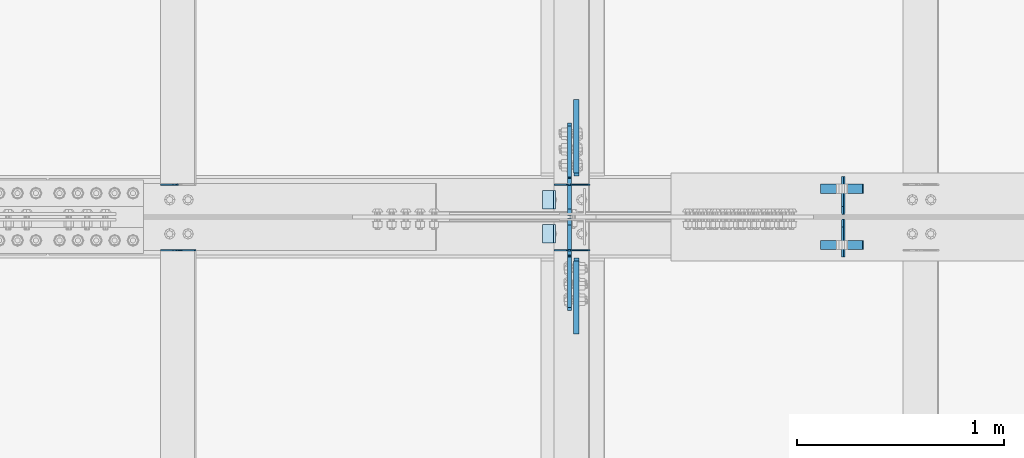
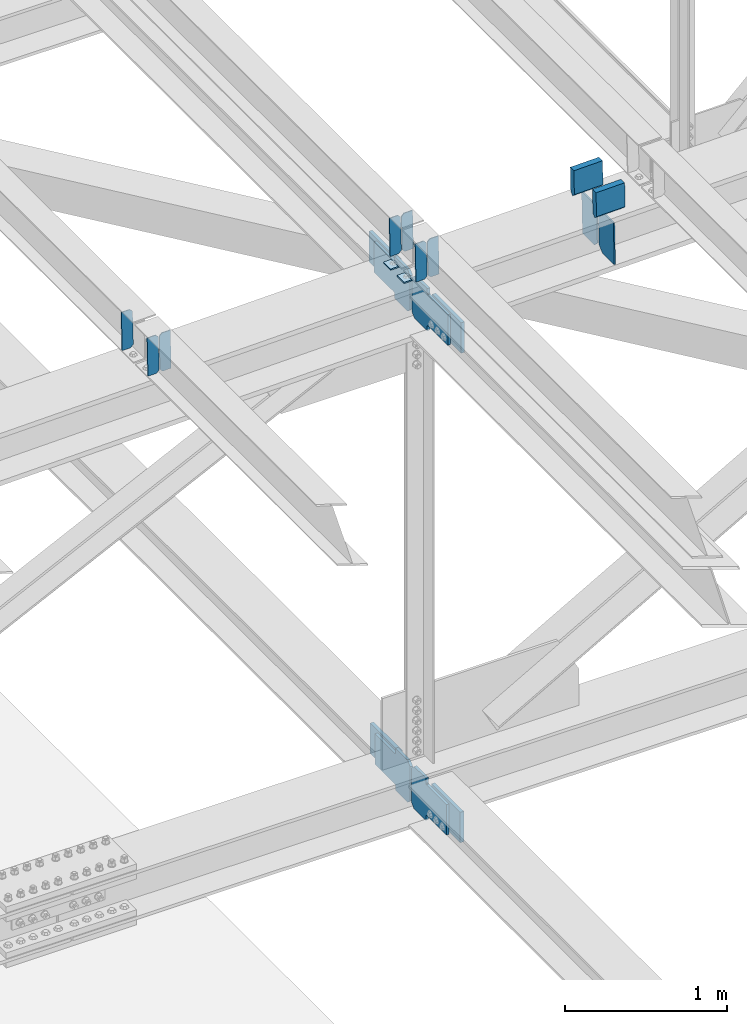
# One storey, part 3318 of 3843: 21 plates, 10 elements without a shape of their own.
"""IFC2X3 building model written with IfcOpenShell, lengths in millimetres."""

from ifc_helpers import new_model, si_unit, frame, origin_with_axes, place, context, subcontext, project, spatial, faceted_brep, material, type_object, element, aggregate, save


model = new_model("IFC2X3")

# Units and contexts
model_context = context("Model", 3, precision=1e-05, world=origin_with_axes())
body_context = subcontext(model_context, "Body", "Model", "MODEL_VIEW")
ifc_project = project(units=[si_unit("LENGTHUNIT", "METRE", prefix="MILLI"), si_unit("AREAUNIT", "SQUARE_METRE"), si_unit("VOLUMEUNIT", "CUBIC_METRE"), si_unit("MASSUNIT", "GRAM", prefix="KILO"), si_unit("TIMEUNIT", "SECOND"), si_unit("PLANEANGLEUNIT", "RADIAN"), si_unit("SOLIDANGLEUNIT", "STERADIAN"), si_unit("THERMODYNAMICTEMPERATUREUNIT", "DEGREE_CELSIUS"), si_unit("LUMINOUSINTENSITYUNIT", "LUMEN")], contexts=[model_context])

# Site, building, storey
site_placement = place(None, origin_with_axes())
site = spatial("IfcSite", under=ifc_project, at=site_placement, CompositionType="ELEMENT")
building_placement = place(site_placement, origin_with_axes())
building = spatial("IfcBuilding", under=site, at=building_placement, Name="Undefined", CompositionType="ELEMENT")
storey_placement = place(building_placement, origin_with_axes())
storey = spatial("IfcBuildingStorey", under=building, at=storey_placement, Name="Undefined", CompositionType="ELEMENT", Elevation=0.0)

# Assembly, plates
assembly_1_placement = place(storey_placement, origin_with_axes())
assembly_1 = element("IfcElementAssembly", 1, at=assembly_1_placement, inside=storey, Name="BEAM", AssemblyPlace="NOTDEFINED", PredefinedType="RIGID_FRAME")
ifc_material = material(Name="STEEL/A572-50")
plate_type_1 = type_object("IfcPlateType", PredefinedType="NOTDEFINED")
plate_1_placement = place(assembly_1_placement, frame((70338.6964783576, 59070.7300501476, 46245.3545514179), z_axis=(-0.0211520985042007, 0.00048581000014383, 0.999776151304637), x_axis=(-0.999776269336729, -1.02780000340977e-05, -0.0211520960071139)))
plate_1 = element("IfcPlate", 2, at=plate_1_placement, type_object=plate_type_1, material=ifc_material, Name="PLATE", context=body_context, shape_type="Brep", body=[
    faceted_brep([(0.0, -3.17499999999927, 0.0), (6.83940015733242e-10, -3.17499999996653, 288.924999998613), (6.54836185276508e-10, 3.17500000001746, 288.924999998591), (0.0, 3.17499999999927, 0.0), (60.3250007643655, -3.17500000017753, 288.924999998606), (60.3250007643219, 3.17499999979918, 288.924999998584), (79.3750000013097, -3.17500000025029, 269.875000761494), (79.375000001266, 3.17499999972642, 269.875000761487), (79.375000000713, -3.17500000026484, 19.0499992370605), (79.3750000006985, 3.17499999971187, 19.0499992370533), (60.325000763667, -3.17500000020664, -1.45519152283669e-11), (60.3250007636234, 3.17499999977736, -3.63797880709171e-11)], [[[0, 1, 2, 3]], [[1, 4, 5, 2]], [[4, 6, 7, 5]], [[6, 8, 9, 7]], [[8, 10, 11, 9]], [[10, 0, 3, 11]], [[5, 7, 9, 11, 3, 2]], [[10, 8, 6, 4, 1, 0]]]),
])
plate_2_placement = place(assembly_1_placement, frame((70252.9906576673, 59070.7291690489, 46243.54128803), z_axis=(-0.0211520985042007, 0.00048581000014383, 0.999776151304637), x_axis=(-0.999776269336729, -1.02780000340977e-05, -0.0211520960071139)))
plate_2 = element("IfcPlate", 3, at=plate_2_placement, type_object=plate_type_1, material=ifc_material, Name="PLATE", context=body_context, shape_type="Brep", body=[
    faceted_brep([(4.36557456851006e-11, -3.17499999998836, 19.0499992370969), (6.11180439591408e-10, -3.17499999996653, 269.875000761516), (5.96628524363041e-10, 3.17500000001746, 269.875000761502), (1.45519152283669e-11, 3.17499999998836, 19.0499992370824), (19.0499992376572, -3.17500000003201, 288.924999998606), (19.0499992376281, 3.1749999999447, 288.924999998584), (79.3750000013242, -3.17500000025029, 288.924999998591), (79.3750000013097, 3.1749999997337, 288.92499999857), (79.3750000006548, -3.17500000026484, -2.18278728425503e-11), (79.3750000006403, 3.17499999969732, -2.91038304567337e-11), (19.0499992370023, -3.17500000005384, 0.0), (19.0499992369587, 3.17499999992287, -1.45519152283669e-11)], [[[0, 1, 2, 3]], [[1, 4, 5, 2]], [[4, 6, 7, 5]], [[6, 8, 9, 7]], [[8, 10, 11, 9]], [[10, 0, 3, 11]], [[5, 7, 9, 11, 3, 2]], [[10, 8, 6, 4, 1, 0]]]),
])

assembly_2_placement = place(storey_placement, origin_with_axes())
assembly_2 = element("IfcElementAssembly", 4, at=assembly_2_placement, inside=storey, Name="BEAM", AssemblyPlace="NOTDEFINED", PredefinedType="RIGID_FRAME")
plate_3_placement = place(assembly_2_placement, frame((70338.69647828, 58753.5181641061, 46245.3524337788), z_axis=(-0.0211520984433592, -0.000479824000096415, 0.999776154196714), x_axis=(-0.999776269357268, 1.0337000006824e-05, -0.0211520950075907)))
plate_3 = element("IfcPlate", 5, at=plate_3_placement, type_object=plate_type_1, material=ifc_material, Name="PLATE", context=body_context, shape_type="Brep", body=[
    faceted_brep([(0.0, -3.17499999999927, 0.0), (6.83940015733242e-10, -3.17499999996653, 288.924999998613), (6.54836185276508e-10, 3.17500000001746, 288.924999998591), (0.0, 3.17499999999927, 0.0), (60.3250007643655, -3.17500000017753, 288.924999998606), (60.3250007643219, 3.17499999979918, 288.924999998584), (79.3750000013097, -3.17500000025029, 269.875000761494), (79.375000001266, 3.17499999972642, 269.875000761487), (79.375000000713, -3.17500000026484, 19.0499992370605), (79.3750000006985, 3.17499999971187, 19.0499992370533), (60.325000763667, -3.17500000020664, -1.45519152283669e-11), (60.3250007636234, 3.17499999977736, -3.63797880709171e-11)], [[[0, 1, 2, 3]], [[1, 4, 5, 2]], [[4, 6, 7, 5]], [[6, 8, 9, 7]], [[8, 10, 11, 9]], [[10, 0, 3, 11]], [[5, 7, 9, 11, 3, 2]], [[10, 8, 6, 4, 1, 0]]]),
])
plate_4_placement = place(assembly_2_placement, frame((70252.9906575897, 58753.5190343468, 46243.5391703861), z_axis=(-0.0211520984433592, -0.000479824000096415, 0.999776154196714), x_axis=(-0.999776269357268, 1.0337000006824e-05, -0.0211520950075907)))
plate_4 = element("IfcPlate", 6, at=plate_4_placement, type_object=plate_type_1, material=ifc_material, Name="PLATE", context=body_context, shape_type="Brep", body=[
    faceted_brep([(4.36557456851006e-11, -3.17499999998836, 19.0499992370969), (6.11180439591408e-10, -3.17499999996653, 269.875000761516), (5.96628524363041e-10, 3.17500000001746, 269.875000761502), (1.45519152283669e-11, 3.17499999998836, 19.0499992370824), (19.0499992376572, -3.17500000003201, 288.924999998606), (19.0499992376281, 3.1749999999447, 288.924999998584), (79.3750000013242, -3.17500000025029, 288.924999998591), (79.3750000013097, 3.1749999997337, 288.92499999857), (79.3750000006548, -3.17500000026484, -2.18278728425503e-11), (79.3750000006403, 3.17499999969732, -2.91038304567337e-11), (19.0499992370023, -3.17500000005384, 0.0), (19.0499992369587, 3.17499999992287, -1.45519152283669e-11)], [[[0, 1, 2, 3]], [[1, 4, 5, 2]], [[4, 6, 7, 5]], [[6, 8, 9, 7]], [[8, 10, 11, 9]], [[10, 0, 3, 11]], [[5, 7, 9, 11, 3, 2]], [[10, 8, 6, 4, 1, 0]]]),
])

# Assembly, plate
assembly_3_placement = place(storey_placement, origin_with_axes())
assembly_3 = element("IfcElementAssembly", 7, at=assembly_3_placement, inside=storey, Name="BEAM", AssemblyPlace="NOTDEFINED", PredefinedType="RIGID_FRAME")
plate_5_placement = place(assembly_3_placement, frame((68347.990661072, 59070.7407155842, 46203.2555883224), z_axis=(-0.0211520981150825, 0.000447354000119958, 0.999776169259764), x_axis=(-0.999776269336729, -1.02780000340977e-05, -0.0211520960071139)))
plate_5 = element("IfcPlate", 8, at=plate_5_placement, type_object=plate_type_1, material=ifc_material, Name="PLATE", context=body_context, shape_type="Brep", body=[
    faceted_brep([(4.36557456851006e-11, -3.17499999998836, 19.0499992370969), (6.11180439591408e-10, -3.17499999996653, 269.875000761516), (5.96628524363041e-10, 3.17500000001746, 269.875000761502), (1.45519152283669e-11, 3.17499999998836, 19.0499992370824), (19.0499992376572, -3.17500000003201, 288.924999998606), (19.0499992376281, 3.1749999999447, 288.924999998584), (79.3750000013242, -3.17500000025029, 288.924999998591), (79.3750000013097, 3.1749999997337, 288.92499999857), (79.3750000006548, -3.17500000026484, -2.18278728425503e-11), (79.3750000006403, 3.17499999969732, -2.91038304567337e-11), (19.0499992370023, -3.17500000005384, 0.0), (19.0499992369587, 3.17499999992287, -1.45519152283669e-11)], [[[0, 1, 2, 3]], [[1, 4, 5, 2]], [[4, 6, 7, 5]], [[6, 8, 9, 7]], [[8, 10, 11, 9]], [[10, 0, 3, 11]], [[5, 7, 9, 11, 3, 2]], [[10, 8, 6, 4, 1, 0]]]),
])
aggregate(assembly_3, [plate_5])

# Assembly, plates
assembly_4_placement = place(storey_placement, origin_with_axes())
assembly_4 = element("IfcElementAssembly", 9, at=assembly_4_placement, inside=storey, Name="BEAM", AssemblyPlace="NOTDEFINED", PredefinedType="RIGID_FRAME")
plate_6_placement = place(assembly_4_placement, frame((68433.6964783078, 58753.5100877052, 46205.0651386453), z_axis=(-0.0211520981762442, -0.000452761999920767, 0.999776166824012), x_axis=(-0.999776269357268, 1.0337000006824e-05, -0.0211520950075907)))
plate_6 = element("IfcPlate", 10, at=plate_6_placement, type_object=plate_type_1, material=ifc_material, Name="PLATE", context=body_context, shape_type="Brep", body=[
    faceted_brep([(0.0, -3.17499999999927, 0.0), (6.83940015733242e-10, -3.17499999996653, 288.924999998613), (6.54836185276508e-10, 3.17500000001746, 288.924999998591), (0.0, 3.17499999999927, 0.0), (60.3250007643655, -3.17500000017753, 288.924999998606), (60.3250007643219, 3.17499999979918, 288.924999998584), (79.3750000013097, -3.17500000025029, 269.875000761494), (79.375000001266, 3.17499999972642, 269.875000761487), (79.375000000713, -3.17500000026484, 19.0499992370605), (79.3750000006985, 3.17499999971187, 19.0499992370533), (60.325000763667, -3.17500000020664, -1.45519152283669e-11), (60.3250007636234, 3.17499999977736, -3.63797880709171e-11)], [[[0, 1, 2, 3]], [[1, 4, 5, 2]], [[4, 6, 7, 5]], [[6, 8, 9, 7]], [[8, 10, 11, 9]], [[10, 0, 3, 11]], [[5, 7, 9, 11, 3, 2]], [[10, 8, 6, 4, 1, 0]]]),
])
plate_7_placement = place(assembly_4_placement, frame((68347.9906576166, 58753.5109088671, 46203.2518752305), z_axis=(-0.0211520981762442, -0.000452761999920767, 0.999776166824012), x_axis=(-0.999776269357268, 1.0337000006824e-05, -0.0211520950075907)))
plate_7 = element("IfcPlate", 11, at=plate_7_placement, type_object=plate_type_1, material=ifc_material, Name="PLATE", context=body_context, shape_type="Brep", body=[
    faceted_brep([(4.36557456851006e-11, -3.17499999998836, 19.0499992370969), (6.11180439591408e-10, -3.17499999996653, 269.875000761516), (5.96628524363041e-10, 3.17500000001746, 269.875000761502), (1.45519152283669e-11, 3.17499999998836, 19.0499992370824), (19.0499992376572, -3.17500000003201, 288.924999998606), (19.0499992376281, 3.1749999999447, 288.924999998584), (79.3750000013242, -3.17500000025029, 288.924999998591), (79.3750000013097, 3.1749999997337, 288.92499999857), (79.3750000006548, -3.17500000026484, -2.18278728425503e-11), (79.3750000006403, 3.17499999969732, -2.91038304567337e-11), (19.0499992370023, -3.17500000005384, 0.0), (19.0499992369587, 3.17499999992287, -1.45519152283669e-11)], [[[0, 1, 2, 3]], [[1, 4, 5, 2]], [[4, 6, 7, 5]], [[6, 8, 9, 7]], [[8, 10, 11, 9]], [[10, 0, 3, 11]], [[5, 7, 9, 11, 3, 2]], [[10, 8, 6, 4, 1, 0]]]),
])
aggregate(assembly_4, [plate_6, plate_7])

assembly_5_placement = place(storey_placement, origin_with_axes())
assembly_5 = element("IfcElementAssembly", 12, at=assembly_5_placement, inside=storey, Name="BEAM", AssemblyPlace="NOTDEFINED", PredefinedType="RIGID_FRAME")
plate_type_2 = type_object("IfcPlateType", PredefinedType="NOTDEFINED")
plate_8_placement = place(assembly_5_placement, frame((71569.3467410042, 58719.7375, 45904.651602728), z_axis=(-0.0199480780058802, 0.0, 0.999801017294877), x_axis=(0.0, 1.0, 0.0)))
plate_8 = element("IfcPlate", 13, at=plate_8_placement, type_object=plate_type_2, material=ifc_material, Name="PL", context=body_context, shape_type="Brep", body=[
    faceted_brep([(0.0, -4.76249999999709, 0.0), (0.0, -4.76249999986612, 316.893560966142), (0.0, 4.7625000000844, 316.893560966142), (0.0, 4.76249999999709, 0.0), (145.746763610834, -4.76249999986612, 316.893560966142), (145.746763610834, 4.7625000000844, 316.893560966142), (184.149999999994, -4.76249999989523, 278.490324577106), (184.149999999994, 4.76250000006985, 278.490324577098), (184.149999999994, -4.76249999999709, 38.4032363890365), (184.149999999994, 4.76249999998254, 38.4032363890365), (145.746763610834, -4.76250000001164, 7.27595761418343e-12), (145.746763610834, 4.76249999995343, 0.0)], [[[0, 1, 2, 3]], [[1, 4, 5, 2]], [[4, 6, 7, 5]], [[6, 8, 9, 7]], [[8, 10, 11, 9]], [[10, 0, 3, 11]], [[5, 7, 9, 11, 3, 2]], [[10, 8, 6, 4, 1, 0]]]),
])
plate_9_placement = place(assembly_5_placement, frame((71569.3467410042, 58926.7125, 45904.651602728), z_axis=(-0.0199480780058802, 0.0, 0.999801017294877), x_axis=(0.0, 1.0, 0.0)))
plate_9 = element("IfcPlate", 14, at=plate_9_placement, type_object=plate_type_2, material=ifc_material, Name="PL", context=body_context, shape_type="Brep", body=[
    faceted_brep([(0.0, -4.76249999999709, 38.4032363890365), (0.0, -4.76249999989523, 278.490324577106), (0.0, 4.76250000006985, 278.490324577098), (0.0, 4.76249999998254, 38.4032363890365), (38.4032363891602, -4.76249999986612, 316.893560966142), (38.4032363891602, 4.7625000000844, 316.893560966142), (184.149999999994, -4.76249999986612, 316.893560966142), (184.149999999994, 4.7625000000844, 316.893560966142), (184.150000000009, -4.76249999999709, 0.0), (184.150000000009, 4.76249999999709, 0.0), (38.4032363891602, -4.76250000001164, 7.27595761418343e-12), (38.4032363891602, 4.76249999995343, 0.0)], [[[0, 1, 2, 3]], [[1, 4, 5, 2]], [[4, 6, 7, 5]], [[6, 8, 9, 7]], [[8, 10, 11, 9]], [[10, 0, 3, 11]], [[5, 7, 9, 11, 3, 2]], [[10, 8, 6, 4, 1, 0]]]),
])
plate_type_3 = type_object("IfcPlateType", PredefinedType="NOTDEFINED")
plate_10_placement = place(assembly_5_placement, frame((71456.2169066286, 59051.428125, 46460.7259145974), z_axis=(0.0217666070074993, 0.0, -0.999763079343992), x_axis=(0.999763079343992, 0.0, 0.0217666070075027)))
plate_10 = element("IfcPlate", 15, at=plate_10_placement, type_object=plate_type_3, material=ifc_material, Name="PLATE", context=body_context, shape_type="Brep", body=[
    faceted_brep([(203.200005058941, -22.2250000000058, -1.16415321826935e-10), (7.27595761418343e-12, -22.2250000000058, -7.27595761418343e-12), (7.27595761418343e-12, 22.2250000000058, -7.27595761418343e-12), (203.200005058941, 22.2250000000058, -1.16415321826935e-10), (203.838531807472, -22.2250000000058, 0.00187068080413155), (203.838531807472, 22.2250000000058, 0.00187068080413155), (203.310341304641, -22.2250000000058, 180.861817383484), (0.04046799018397, -22.2250000000058, 180.907287948779), (203.245434494536, 0.0133131837355904, 203.086833080139), (0.0454396034692763, 0.0133129994646879, 203.132287829787), (0.0404679902494536, 22.2250000000058, 180.907288225317), (203.310341303353, 22.2250000000058, 180.861817822159)], [[[0, 1, 2, 3]], [[4, 0, 3, 5]], [[1, 0, 4, 6, 7]], [[7, 6, 8, 9]], [[2, 1, 7, 9, 10]], [[5, 3, 2, 10, 11]], [[6, 4, 5, 11, 8]], [[10, 9, 8, 11]]]),
])
plate_11_placement = place(assembly_5_placement, frame((71456.2169066286, 58778.378125, 46460.7259145974), z_axis=(0.0217666070074993, 0.0, -0.999763079343992), x_axis=(0.999763079343992, 0.0, 0.0217666070075027)))
plate_11 = element("IfcPlate", 16, at=plate_11_placement, type_object=plate_type_3, material=ifc_material, Name="PLATE", context=body_context, shape_type="Brep", body=[
    faceted_brep([(203.200005058941, -22.2250000000058, -1.16415321826935e-10), (7.27595761418343e-12, -22.2250000000058, -7.27595761418343e-12), (7.27595761418343e-12, 22.2250000000058, -7.27595761418343e-12), (203.200005058941, 22.2250000000058, -1.16415321826935e-10), (203.838531807472, -22.2250000000058, 0.00187068080413155), (203.838531807472, 22.2250000000058, 0.00187068080413155), (203.310341304641, -22.2250000000058, 180.861817383484), (0.04046799018397, -22.2250000000058, 180.907287948779), (203.245434494536, 0.0133131837355904, 203.086833080139), (0.0454396034692763, 0.0133129994646879, 203.132287829787), (0.0404679902494536, 22.2250000000058, 180.907288225317), (203.310341303353, 22.2250000000058, 180.861817822159)], [[[0, 1, 2, 3]], [[4, 0, 3, 5]], [[1, 0, 4, 6, 7]], [[7, 6, 8, 9]], [[2, 1, 7, 9, 10]], [[5, 3, 2, 10, 11]], [[6, 4, 5, 11, 8]], [[10, 9, 8, 11]]]),
])

# Plate
plate_type_4 = type_object("IfcPlateType", PredefinedType="NOTDEFINED")
plate_12_placement = place(assembly_1_placement, frame((70173.7677317981, 59042.3, 46235.5893041541), z_axis=(0.0, -1.0, 0.0), x_axis=(-0.999776270257024, 0.0, -0.0211520550054595)))
plate_12 = element("IfcPlate", 17, at=plate_12_placement, type_object=plate_type_4, material=ifc_material, Name="PLATE", context=body_context, shape_type="Brep", body=[
    faceted_brep([(9.52499999982683, -4.7625000001135, 88.8999999999942), (0.0, 4.76249999999709, 88.9000015258789), (0.0, 4.76249999999709, 0.0), (9.52499999981956, -4.76249999999709, 0.0), (63.4999984608512, -4.76249999988795, 88.8999999999796), (63.4999984608367, -4.76249999988795, -1.45519152283669e-11), (63.4999984608221, 4.76250000013533, -1.45519152283669e-11), (63.4999984608367, 4.76250000013533, 88.8999999999796)], [[[0, 1, 2, 3]], [[4, 5, 6, 7]], [[5, 4, 0, 3]], [[6, 5, 3, 2]], [[7, 6, 2, 1]], [[4, 7, 1, 0]]]),
])

aggregate(assembly_1, [plate_1, plate_2, plate_12])

plate_13_placement = place(assembly_2_placement, frame((70173.7677317981, 58877.2000015258, 46235.5893041541), z_axis=(0.0, -1.0, 0.0), x_axis=(-0.999776270257024, 0.0, -0.0211520550054595)))
plate_13 = element("IfcPlate", 18, at=plate_13_placement, type_object=plate_type_4, material=ifc_material, Name="PLATE", context=body_context, shape_type="Brep", body=[
    faceted_brep([(9.52499999982683, -4.7625000001135, 88.8999999999942), (0.0, 4.76249999999709, 88.9000015258789), (0.0, 4.76249999999709, 0.0), (9.52499999981956, -4.76249999999709, 0.0), (63.4999984608512, -4.76249999988795, 88.8999999999796), (63.4999984608367, -4.76249999988795, -1.45519152283669e-11), (63.4999984608221, 4.76250000013533, -1.45519152283669e-11), (63.4999984608367, 4.76250000013533, 88.8999999999796)], [[[0, 1, 2, 3]], [[4, 5, 6, 7]], [[5, 4, 0, 3]], [[6, 5, 3, 2]], [[7, 6, 2, 1]], [[4, 7, 1, 0]]]),
])

aggregate(assembly_2, [plate_3, plate_4, plate_13])

# Assembly, plates
assembly_6_placement = place(storey_placement, origin_with_axes())
assembly_6 = element("IfcElementAssembly", 19, at=assembly_6_placement, inside=storey, Name="BEAM", AssemblyPlace="NOTDEFINED", PredefinedType="RIGID_FRAME")
plate_type_5 = type_object("IfcPlateType", PredefinedType="NOTDEFINED")
plate_14_placement = place(assembly_6_placement, frame((70240.5250037615, 58922.4437499936, 42221.1706293692), z_axis=(0.0, 0.707106781186548, 0.707106781186548), x_axis=(5.70000238222118e-08, 0.707106781186546, -0.707106781186546)))
plate_14 = element("IfcPlate", 20, at=plate_14_placement, type_object=plate_type_5, material=ifc_material, Name="PLATE", context=body_context, shape_type="Brep", body=[
    faceted_brep([(0.0, -9.52500000000146, 0.0), (-179.602577310166, -9.52499999999418, 179.602577310157), (-179.602577310166, 9.52499999999418, 179.602577310157), (0.0, 9.52500000000146, 0.0), (-179.602577310174, -9.52499999999418, 224.503857915275), (-179.602577310174, 9.52499999999418, 224.503857915275), (-75.7683659063059, -9.52499999999418, 328.338069319128), (-75.7683659063059, 9.52499999999418, 328.338069319128), (-53.2343905924154, -9.52499999999418, 305.804094005245), (-53.2343905924154, 9.52499999999418, 305.804094005245), (-49.114214124269, -9.52499999999418, 303.051080104779), (-49.114214124269, 9.52499999999418, 303.051080104779), (-44.2541346062371, -9.52499999999418, 302.084350182195), (-44.2541346062371, 9.52499999999418, 302.084350182195), (-39.3940550882053, -9.52499999999418, 303.051080104779), (-39.3940550882053, 9.52499999999418, 303.051080104779), (-35.2738786200662, -9.52499999999418, 305.804094005245), (-35.2738786200662, 9.52499999999418, 305.804094005245), (135.350987809788, -9.52499999999418, 476.428960435107), (135.350987809788, 9.52499999999418, 476.428960435107), (296.995597988256, -9.52499999999418, 314.784350256639), (296.995597988256, 9.52499999999418, 314.784350256639), (126.370731558405, -9.52499999999418, 144.159483826777), (126.370731558405, 9.52499999999418, 144.159483826777), (123.617717657935, -9.52499999999418, 140.039307358631), (123.617717657935, 9.52499999999418, 140.039307358631), (122.650987735351, -9.52499999999418, 135.179227840606), (122.650987735351, 9.52499999999418, 135.179227840606), (123.617717657942, -9.52499999999418, 130.319148322567), (123.617717657942, 9.52499999999418, 130.319148322567), (126.370731558409, -9.52499999999418, 126.198971854421), (126.370731558409, 9.52499999999418, 126.198971854421), (148.735492003645, -9.52499999999418, 103.834211398527), (148.735492003645, 9.52499999999418, 103.834211398527), (44.9012806055835, -9.52499999999418, 4.65661287307739e-10), (44.9012806055835, 9.52499999999418, 4.65661287307739e-10)], [[[0, 1, 2, 3]], [[1, 4, 5, 2]], [[4, 6, 7, 5]], [[6, 8, 9, 7]], [[8, 10, 11, 9]], [[10, 12, 13, 11]], [[12, 14, 15, 13]], [[14, 16, 17, 15]], [[16, 18, 19, 17]], [[18, 20, 21, 19]], [[20, 22, 23, 21]], [[22, 24, 25, 23]], [[24, 26, 27, 25]], [[26, 28, 29, 27]], [[28, 30, 31, 29]], [[30, 32, 33, 31]], [[32, 34, 35, 33]], [[34, 0, 3, 35]], [[5, 7, 9, 11, 13, 15, 17, 19, 21, 23, 25, 27, 29, 31, 33, 35, 3, 2]], [[34, 32, 30, 28, 26, 24, 22, 20, 18, 16, 14, 12, 10, 8, 6, 4, 1, 0]]]),
])
plate_15_placement = place(assembly_6_placement, frame((70240.525082214, 58908.1562500069, 42221.1706293764), z_axis=(0.0, -0.707106781186682, 0.707106781186413), x_axis=(0.0, -0.707106781186548, -0.707106781186548)))
plate_15 = element("IfcPlate", 21, at=plate_15_placement, type_object=plate_type_5, material=ifc_material, Name="PLATE", context=body_context, shape_type="Brep", body=[
    faceted_brep([(0.0, -9.52500000000146, 0.0), (-179.602577310166, -9.52499999999418, 179.602577310157), (-179.602577310166, 9.52499999999418, 179.602577310157), (0.0, 9.52500000000146, 0.0), (-179.602577310174, -9.52499999999418, 224.503857915275), (-179.602577310174, 9.52499999999418, 224.503857915275), (-75.7683659063059, -9.52499999999418, 328.338069319128), (-75.7683659063059, 9.52499999999418, 328.338069319128), (-53.2069487223052, -9.52499999999418, 305.776652138817), (-53.2069487223052, 9.52499999999418, 305.776652138817), (-49.0867722541443, -9.52499999999418, 303.023638238357), (-49.0867722541443, 9.52499999999418, 303.023638238357), (-44.2266927361052, -9.52499999999418, 302.056908315784), (-44.2266927361052, 9.52499999999418, 302.056908315784), (-39.3666132180806, -9.52499999999418, 303.023638238383), (-39.3666132180806, 9.52499999999418, 303.023638238383), (-35.2464367499488, -9.52499999999418, 305.776652138857), (-35.2464367499488, 9.52499999999418, 305.776652138857), (135.37842967888, -9.52499999999418, 476.401518568409), (135.37842967888, 9.52499999999418, 476.401518568409), (297.023039858541, -9.52499999999418, 314.756908389458), (297.023039858541, 9.52499999999418, 314.756908389458), (126.398173429698, -9.52499999999418, 144.132041959898), (126.398173429698, 9.52499999999418, 144.132041959898), (123.645159529231, -9.52499999999418, 140.011865491748), (123.645159529231, 9.52499999999418, 140.011865491748), (122.678429606662, -9.52499999999418, 135.151785973712), (122.678429606662, 9.52499999999418, 135.151785973712), (123.64515952926, -9.52499999999418, 130.29170645568), (123.64515952926, 9.52499999999418, 130.29170645568), (126.398173429741, -9.52499999999418, 126.171529987545), (126.398173429741, 9.52499999999418, 126.171529987545), (148.735492003645, -9.52499999999418, 103.834211398527), (148.735492003645, 9.52499999999418, 103.834211398527), (44.9012806055835, -9.52499999999418, 4.65661287307739e-10), (44.9012806055835, 9.52499999999418, 4.65661287307739e-10)], [[[0, 1, 2, 3]], [[1, 4, 5, 2]], [[4, 6, 7, 5]], [[6, 8, 9, 7]], [[8, 10, 11, 9]], [[10, 12, 13, 11]], [[12, 14, 15, 13]], [[14, 16, 17, 15]], [[16, 18, 19, 17]], [[18, 20, 21, 19]], [[20, 22, 23, 21]], [[22, 24, 25, 23]], [[24, 26, 27, 25]], [[26, 28, 29, 27]], [[28, 30, 31, 29]], [[30, 32, 33, 31]], [[32, 34, 35, 33]], [[34, 0, 3, 35]], [[5, 7, 9, 11, 13, 15, 17, 19, 21, 23, 25, 27, 29, 31, 33, 35, 3, 2]], [[34, 32, 30, 28, 26, 24, 22, 20, 18, 16, 14, 12, 10, 8, 6, 4, 1, 0]]]),
])
aggregate(assembly_6, [plate_14, plate_15])

# Plate
plate_16_placement = place(assembly_5_placement, frame((70242.1125702102, 58904.1875000194, 45908.5471681676), z_axis=(0.0, -0.707106781186682, 0.707106781186413), x_axis=(0.0, -0.707106781186548, -0.707106781186548)))
plate_16 = element("IfcPlate", 22, at=plate_16_placement, type_object=plate_type_5, material=ifc_material, Name="PLATE", context=body_context, shape_type="Brep", body=[
    faceted_brep([(0.0, -9.52500000000146, 0.0), (-179.372257236595, -9.52499999999418, 179.372257236611), (-179.372257236595, 9.52499999999418, 179.372257236611), (0.0, 9.52500000000146, 0.0), (-179.372257236595, -9.52499999999418, 224.273537841744), (-179.372257236595, 9.52499999999418, 224.273537841744), (-68.2415877252497, -9.52499999999418, 335.4042073531), (-68.2415877252497, 9.52499999999418, 335.4042073531), (-46.0317183546867, -9.52499999999418, 313.194337982533), (-46.0317183546867, 9.52499999999418, 313.194337982533), (-41.9115418865404, -9.52499999999418, 310.441324082067), (-41.9115418865404, 9.52499999999418, 310.441324082067), (-37.0514623685158, -9.52499999999418, 309.47459415949), (-37.0514623685158, 9.52499999999418, 309.47459415949), (-32.1913828504621, -9.52499999999418, 310.441324082074), (-32.1913828504621, 9.52499999999418, 310.441324082074), (-28.0712063823303, -9.52499999999418, 313.194337982544), (-28.0712063823303, 9.52499999999418, 313.194337982544), (142.553660038349, -9.52499999999418, 483.819204403224), (142.553660038349, 9.52499999999418, 483.819204403224), (304.198270216802, -9.52499999999418, 322.174594224756), (304.198270216802, 9.52499999999418, 322.174594224756), (133.573403796123, -9.52499999999418, 151.549727804077), (133.573403796123, 9.52499999999418, 151.549727804077), (130.820389895656, -9.52499999999418, 147.429551335934), (130.820389895656, 9.52499999999418, 147.429551335934), (129.853659973072, -9.52499999999418, 142.569471817906), (129.853659973072, 9.52499999999418, 142.569471817906), (130.820389895656, -9.52499999999418, 137.70939229987), (130.820389895656, 9.52499999999418, 137.70939229987), (133.573403796123, -9.52499999999418, 133.58921583172), (133.573403796123, 9.52499999999418, 133.58921583172), (156.031950102854, -9.52499999999418, 111.130669497732), (156.031950102854, 9.52499999999418, 111.130669497732), (44.9012806055835, -9.52499999999418, 4.65661287307739e-10), (44.9012806055835, 9.52499999999418, 4.65661287307739e-10)], [[[0, 1, 2, 3]], [[1, 4, 5, 2]], [[4, 6, 7, 5]], [[6, 8, 9, 7]], [[8, 10, 11, 9]], [[10, 12, 13, 11]], [[12, 14, 15, 13]], [[14, 16, 17, 15]], [[16, 18, 19, 17]], [[18, 20, 21, 19]], [[20, 22, 23, 21]], [[22, 24, 25, 23]], [[24, 26, 27, 25]], [[26, 28, 29, 27]], [[28, 30, 31, 29]], [[30, 32, 33, 31]], [[32, 34, 35, 33]], [[34, 0, 3, 35]], [[5, 7, 9, 11, 13, 15, 17, 19, 21, 23, 25, 27, 29, 31, 33, 35, 3, 2]], [[34, 32, 30, 28, 26, 24, 22, 20, 18, 16, 14, 12, 10, 8, 6, 4, 1, 0]]]),
])

plate_17_placement = place(assembly_5_placement, frame((70242.1124993986, 58926.4125, 45908.5471668424), z_axis=(0.0, 0.707106781186548, 0.707106781186548), x_axis=(5.70000238222118e-08, 0.707106781186546, -0.707106781186546)))
plate_17 = element("IfcPlate", 23, at=plate_17_placement, type_object=plate_type_5, material=ifc_material, Name="PLATE", context=body_context, shape_type="Brep", body=[
    faceted_brep([(0.0, -9.52500000000146, 0.0), (-179.372257236595, -9.52499999999418, 179.372257236611), (-179.372257236595, 9.52499999999418, 179.372257236611), (0.0, 9.52500000000146, 0.0), (-179.372257236595, -9.52499999999418, 224.273537841744), (-179.372257236595, 9.52499999999418, 224.273537841744), (-68.2415877252497, -9.52499999999418, 335.4042073531), (-68.2415877252497, 9.52499999999418, 335.4042073531), (-46.0302843047339, -9.52499999999418, 313.192903905263), (-46.0302843047339, 9.52499999999418, 313.192903905263), (-41.9101078365911, -9.52499999999418, 310.439890004782), (-41.9101078365911, 9.52499999999418, 310.439890004782), (-37.0500283185593, -9.52499999999418, 309.473160082212), (-37.0500283185593, 9.52499999999418, 309.473160082212), (-32.1899488005201, -9.52499999999418, 310.439890004796), (-32.1899488005201, 9.52499999999418, 310.439890004796), (-28.0697723323774, -9.52499999999418, 313.192903905263), (-28.0697723323774, 9.52499999999418, 313.192903905263), (142.555094101945, -9.52499999999418, 483.817770339607), (142.555094101945, 9.52499999999418, 483.817770339607), (304.199704280416, -9.52499999999418, 322.173160161125), (304.199704280416, 9.52499999999418, 322.173160161125), (133.574837846083, -9.52499999999418, 151.54829372681), (133.574837846083, 9.52499999999418, 151.54829372681), (130.821823945613, -9.52499999999418, 147.428117258663), (130.821823945613, 9.52499999999418, 147.428117258663), (129.855094023025, -9.52499999999418, 142.568037740624), (129.855094023025, 9.52499999999418, 142.568037740624), (130.821823945616, -9.52499999999418, 137.7079582226), (130.821823945616, 9.52499999999418, 137.7079582226), (133.574837846083, -9.52499999999418, 133.587781754453), (133.574837846083, 9.52499999999418, 133.587781754453), (156.031950102854, -9.52499999999418, 111.130669497732), (156.031950102854, 9.52499999999418, 111.130669497732), (44.9012806055835, -9.52499999999418, 4.65661287307739e-10), (44.9012806055835, 9.52499999999418, 4.65661287307739e-10)], [[[0, 1, 2, 3]], [[1, 4, 5, 2]], [[4, 6, 7, 5]], [[6, 8, 9, 7]], [[8, 10, 11, 9]], [[10, 12, 13, 11]], [[12, 14, 15, 13]], [[14, 16, 17, 15]], [[16, 18, 19, 17]], [[18, 20, 21, 19]], [[20, 22, 23, 21]], [[22, 24, 25, 23]], [[24, 26, 27, 25]], [[26, 28, 29, 27]], [[28, 30, 31, 29]], [[30, 32, 33, 31]], [[32, 34, 35, 33]], [[34, 0, 3, 35]], [[5, 7, 9, 11, 13, 15, 17, 19, 21, 23, 25, 27, 29, 31, 33, 35, 3, 2]], [[34, 32, 30, 28, 26, 24, 22, 20, 18, 16, 14, 12, 10, 8, 6, 4, 1, 0]]]),
])

aggregate(assembly_5, [plate_8, plate_9, plate_10, plate_11, plate_16, plate_17])

# Assembly, plate
assembly_7_placement = place(storey_placement, origin_with_axes())
assembly_7 = element("IfcElementAssembly", 24, at=assembly_7_placement, inside=storey, Name="BEAM", AssemblyPlace="NOTDEFINED", PredefinedType="RIGID_FRAME")
plate_type_6 = type_object("IfcPlateType", PredefinedType="NOTDEFINED")
plate_18_placement = place(assembly_7_placement, frame((70273.8624914684, 59128.024999695, 45921.2416052373), z_axis=(0.0, 1.0, 0.0), x_axis=(0.0, 0.0, 1.0)))
plate_18 = element("IfcPlate", 25, at=plate_18_placement, type_object=plate_type_6, material=ifc_material, Name="PLATE", context=body_context, shape_type="Brep", body=[
    faceted_brep([(0.0, -12.6999999999971, 0.0), (0.0147141397246742, -12.7000000013795, 355.599999695551), (0.0147141397246742, 12.6999999986292, 355.599999695653), (0.0, 12.6999999999971, 0.0), (228.629514935208, -12.7000000013795, 355.599999692029), (228.629514935208, 12.6999999986292, 355.599999692131), (228.614714160503, -12.6999999999971, 4.36557456851006e-11), (228.614714160503, 12.6999999999971, 1.45519152283669e-10)], [[[0, 1, 2, 3]], [[1, 4, 5, 2]], [[4, 6, 7, 5]], [[6, 0, 3, 7]], [[5, 7, 3, 2]], [[6, 4, 1, 0]]]),
])
aggregate(assembly_7, [plate_18])

assembly_8_placement = place(storey_placement, origin_with_axes())
assembly_8 = element("IfcElementAssembly", 26, at=assembly_8_placement, inside=storey, Name="BEAM", AssemblyPlace="NOTDEFINED", PredefinedType="RIGID_FRAME")
plate_19_placement = place(assembly_8_placement, frame((70273.8624914684, 58346.9750001952, 45921.2583487744), z_axis=(0.0, 1.0, 0.0), x_axis=(0.0, 0.0, 1.0)))
plate_19 = element("IfcPlate", 27, at=plate_19_placement, type_object=plate_type_6, material=ifc_material, Name="PLATE", context=body_context, shape_type="Brep", body=[
    faceted_brep([(0.0, -12.6999999999971, 0.0), (0.0147141397246742, -12.7000000013795, 355.599999695551), (0.0147141397246742, 12.6999999986292, 355.599999695653), (0.0, 12.6999999999971, 0.0), (228.599998464349, -12.7000000013795, 355.599999691767), (228.599998464349, 12.6999999986292, 355.599999691869), (228.585197689645, -12.6999999999825, -2.18278728425503e-10), (228.585197689645, 12.7000000000116, -1.16415321826935e-10)], [[[0, 1, 2, 3]], [[1, 4, 5, 2]], [[4, 6, 7, 5]], [[6, 0, 3, 7]], [[5, 7, 3, 2]], [[6, 4, 1, 0]]]),
])
aggregate(assembly_8, [plate_19])

assembly_9_placement = place(storey_placement, origin_with_axes())
assembly_9 = element("IfcElementAssembly", 28, at=assembly_9_placement, inside=storey, Name="BEAM", AssemblyPlace="NOTDEFINED", PredefinedType="RIGID_FRAME")
plate_20_placement = place(assembly_9_placement, frame((70275.4501501836, 58716.8625001892, 42462.3103680897), z_axis=(0.0, 0.0, -1.0), x_axis=(0.0, -1.0, 0.0)))
plate_20 = element("IfcPlate", 29, at=plate_20_placement, type_object=plate_type_6, material=ifc_material, Name="PLATE", context=body_context, shape_type="Brep", body=[
    faceted_brep([(0.0, -12.6999999999971, 0.0), (1.30967237055302e-10, -12.6999999999971, 228.600000023711), (1.30967237055302e-10, 12.6999999999971, 228.600000023711), (0.0, 12.6999999999971, 0.0), (355.600000000137, -12.6999999999971, 228.600000023711), (355.600000000137, 12.6999999999971, 228.600000023711), (355.599999999999, -12.7000000000007, 0.0), (355.599999999999, 12.7000000000007, 0.0)], [[[0, 1, 2, 3]], [[1, 4, 5, 2]], [[4, 6, 7, 5]], [[6, 0, 3, 7]], [[5, 7, 3, 2]], [[6, 4, 1, 0]]]),
])
aggregate(assembly_9, [plate_20])

assembly_10_placement = place(storey_placement, origin_with_axes())
assembly_10 = element("IfcElementAssembly", 30, at=assembly_10_placement, inside=storey, Name="BEAM", AssemblyPlace="NOTDEFINED", PredefinedType="RIGID_FRAME")
plate_21_placement = place(assembly_10_placement, frame((70275.4501501836, 59469.3374400071, 42462.3495837571), z_axis=(0.0, 0.0, -1.0), x_axis=(0.0, -1.0, 0.0)))
plate_21 = element("IfcPlate", 31, at=plate_21_placement, type_object=plate_type_6, material=ifc_material, Name="PLATE", context=body_context, shape_type="Brep", body=[
    faceted_brep([(0.0, -12.6999999999971, 0.0), (1.30967237055302e-10, -12.6999999999971, 228.600000023711), (1.30967237055302e-10, 12.6999999999971, 228.600000023711), (0.0, 12.6999999999971, 0.0), (355.600000000137, -12.6999999999971, 228.600000023711), (355.600000000137, 12.6999999999971, 228.600000023711), (355.599999999999, -12.7000000000007, 0.0), (355.599999999999, 12.7000000000007, 0.0)], [[[0, 1, 2, 3]], [[1, 4, 5, 2]], [[4, 6, 7, 5]], [[6, 0, 3, 7]], [[5, 7, 3, 2]], [[6, 4, 1, 0]]]),
])
aggregate(assembly_10, [plate_21])

save(model, "model.ifc")
